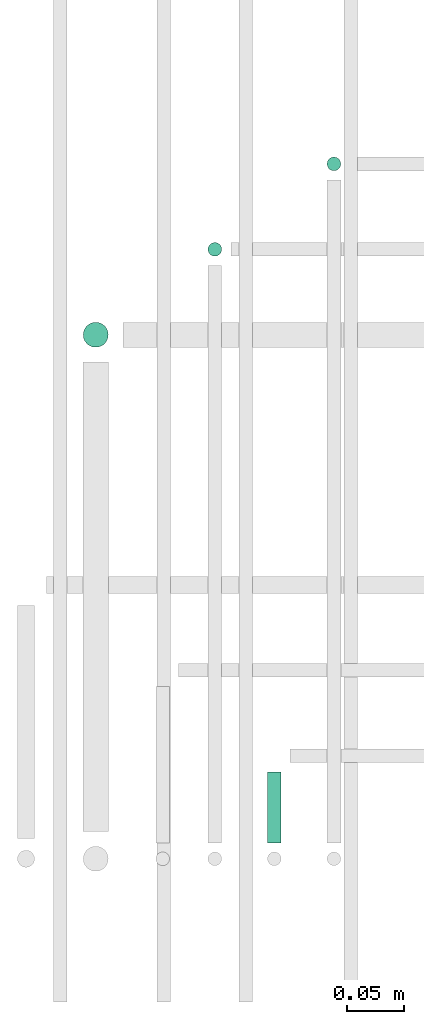
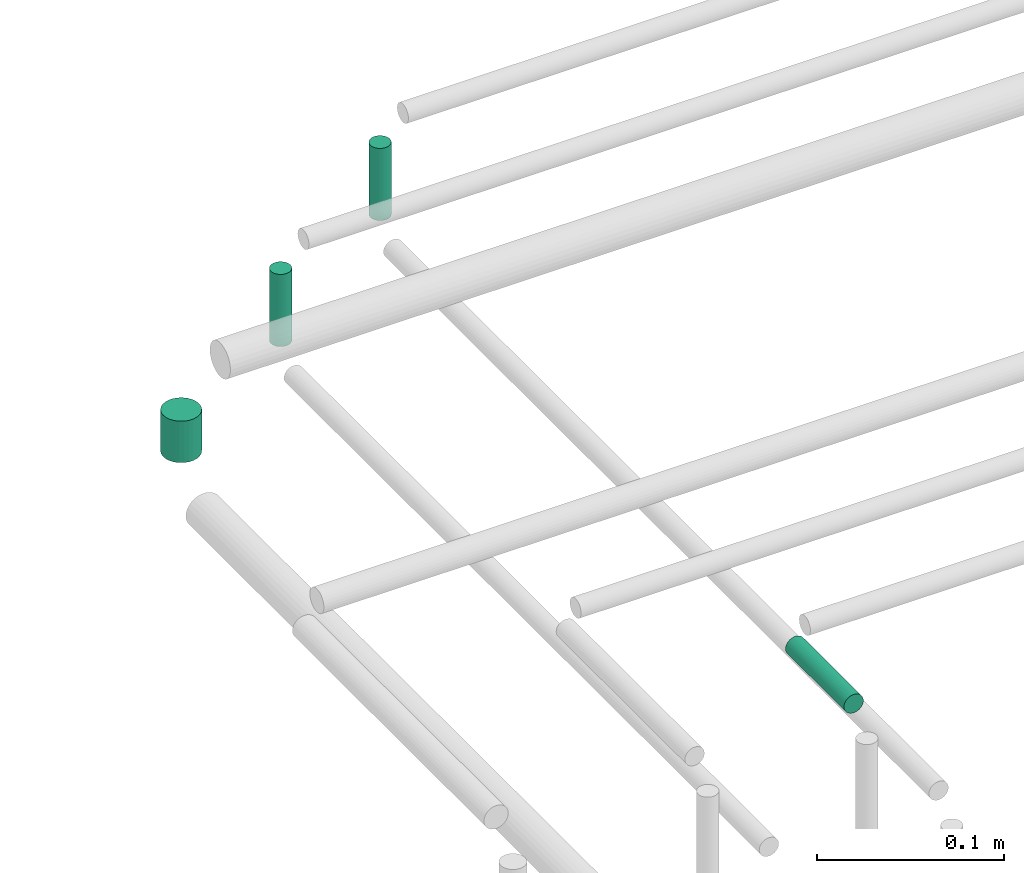
# One storey, part 250 of 331: 4 flow segments.
"""IFC2X3 building model written with IfcOpenShell, lengths in millimetres."""

from ifc_helpers import new_model, entity, si_unit, converted_unit, derived_unit, direction, frame, frame_2d, origin, origin_2d_with_axis, place, context, subcontext, project, spatial, circle, extrude, type_object, element, save


model = new_model("IFC2X3")

# Units and contexts
model_context = context("Model", 3, precision=0.01, world=origin(), true_north=direction((6.12303176911189e-17, 1.0)))
body_context = subcontext(model_context, "Body", "Model", "MODEL_VIEW")
ifc_project = project(units=[si_unit("LENGTHUNIT", "METRE", prefix="MILLI"), si_unit("AREAUNIT", "SQUARE_METRE"), si_unit("VOLUMEUNIT", "CUBIC_METRE"), converted_unit("PLANEANGLEUNIT", "DEGREE", entity("IfcRatioMeasure", 0.0174532925199433), si_unit("PLANEANGLEUNIT", "RADIAN"), dimensions=[0, 0, 0, 0, 0, 0, 0]), si_unit("MASSUNIT", "GRAM", prefix="KILO"), derived_unit("MASSDENSITYUNIT", [(si_unit("MASSUNIT", "GRAM", prefix="KILO"), 1), (si_unit("LENGTHUNIT", "METRE"), -3)]), derived_unit("MOMENTOFINERTIAUNIT", [(si_unit("LENGTHUNIT", "METRE"), 4)]), si_unit("TIMEUNIT", "SECOND"), si_unit("FREQUENCYUNIT", "HERTZ"), si_unit("THERMODYNAMICTEMPERATUREUNIT", "DEGREE_CELSIUS"), derived_unit("THERMALTRANSMITTANCEUNIT", [(si_unit("MASSUNIT", "GRAM", prefix="KILO"), 1), (si_unit("THERMODYNAMICTEMPERATUREUNIT", "KELVIN"), -1), (si_unit("TIMEUNIT", "SECOND"), -3)]), derived_unit("VOLUMETRICFLOWRATEUNIT", [(si_unit("LENGTHUNIT", "METRE"), 3), (si_unit("TIMEUNIT", "SECOND"), -1)]), derived_unit("MASSFLOWRATEUNIT", [(si_unit("MASSUNIT", "GRAM", prefix="KILO"), 1), (si_unit("TIMEUNIT", "SECOND"), -1)]), derived_unit("ROTATIONALFREQUENCYUNIT", [(si_unit("TIMEUNIT", "SECOND"), -1)]), si_unit("ELECTRICCURRENTUNIT", "AMPERE"), si_unit("ELECTRICVOLTAGEUNIT", "VOLT"), si_unit("POWERUNIT", "WATT"), si_unit("FORCEUNIT", "NEWTON", prefix="KILO"), si_unit("ILLUMINANCEUNIT", "LUX"), si_unit("LUMINOUSFLUXUNIT", "LUMEN"), si_unit("LUMINOUSINTENSITYUNIT", "CANDELA"), derived_unit("USERDEFINED", [(si_unit("MASSUNIT", "GRAM", prefix="KILO"), -1), (si_unit("LENGTHUNIT", "METRE"), -2), (si_unit("TIMEUNIT", "SECOND"), 3), (si_unit("LUMINOUSFLUXUNIT", "LUMEN"), 1)]), derived_unit("LINEARVELOCITYUNIT", [(si_unit("LENGTHUNIT", "METRE"), 1), (si_unit("TIMEUNIT", "SECOND"), -1)]), si_unit("PRESSUREUNIT", "PASCAL"), derived_unit("USERDEFINED", [(si_unit("LENGTHUNIT", "METRE"), -2), (si_unit("MASSUNIT", "GRAM", prefix="KILO"), 1), (si_unit("TIMEUNIT", "SECOND"), -2)]), derived_unit("LINEARFORCEUNIT", [(si_unit("MASSUNIT", "GRAM", prefix="KILO"), 1), (si_unit("LENGTHUNIT", "METRE"), 1), (si_unit("TIMEUNIT", "SECOND"), -2), (si_unit("LENGTHUNIT", "METRE"), -1)]), derived_unit("PLANARFORCEUNIT", [(si_unit("MASSUNIT", "GRAM", prefix="KILO"), 1), (si_unit("LENGTHUNIT", "METRE"), 1), (si_unit("TIMEUNIT", "SECOND"), -2), (si_unit("LENGTHUNIT", "METRE"), -2)])], contexts=[model_context])

# Site, building, storey
site_placement = place(None, frame((0.0, -0.00077364408347762, 0.0)))
site = spatial("IfcSite", under=ifc_project, at=site_placement, CompositionType="ELEMENT")
building_placement = place(site_placement, origin())
building = spatial("IfcBuilding", under=site, at=building_placement, CompositionType="ELEMENT")
storey_placement = place(building_placement, origin())
storey = spatial("IfcBuildingStorey", under=building, at=storey_placement, CompositionType="ELEMENT", Elevation=0.0)

# Flow segments
pipe_segment_type = type_object("IfcPipeSegmentType", PredefinedType="NOTDEFINED")
flow_segment_1_placement = place(storey_placement, frame((18973.7737980249, 8668.02529159145, 14489.0)))
element("IfcFlowSegment", 1, at=flow_segment_1_placement, inside=storey, type_object=pipe_segment_type, context=body_context, shape_type="SweptSolid", body=[
    extrude(circle(Radius=6.0, at=frame_2d((0.0, 1.08286712929839e-12), x_axis=(1.0, 0.0))), frame((7.5952722359167, 7.59527223591454, 0.0)), (0.0, 0.0, 1.0), 46.9999998910854),
])
flow_segment_2_placement = place(storey_placement, frame((18921.4061109664, 8079.62056382735, 14542.4047277641)))
element("IfcFlowSegment", 2, at=flow_segment_2_placement, inside=storey, type_object=pipe_segment_type, context=body_context, shape_type="SweptSolid", body=[
    extrude(circle(Radius=6.0, at=frame_2d((2.16573425859679e-12, 0.0), x_axis=(1.0, 0.0))), frame((7.59527223591887, 0.0, 7.5952722359167), z_axis=(0.0, 1.0, 0.0), x_axis=(-1.0, 0.0, 0.0)), (0.0, 0.0, 1.0), 62.3893800219506),
])
flow_segment_3_placement = place(storey_placement, frame((18759.6577850481, 8513.02529159144, 14499.0)))
element("IfcFlowSegment", 3, at=flow_segment_3_placement, inside=storey, type_object=pipe_segment_type, context=body_context, shape_type="SweptSolid", body=[
    extrude(circle(Radius=11.0, at=origin_2d_with_axis()), frame((12.5952722359156, 12.5952722359156, 0.0)), (0.0, 0.0, 1.0), 26.9999998910856),
])
flow_segment_4_placement = place(storey_placement, frame((18869.2157915365, 8593.02529159146, 14489.0)))
element("IfcFlowSegment", 4, at=flow_segment_4_placement, inside=storey, type_object=pipe_segment_type, context=body_context, shape_type="SweptSolid", body=[
    extrude(circle(Radius=6.0, at=frame_2d((0.0, 1.08286712929839e-12), x_axis=(1.0, 0.0))), frame((7.5952722359167, 7.59527223591454, 0.0)), (0.0, 0.0, 1.0), 46.9999998911005),
])

save(model, "model.ifc")
